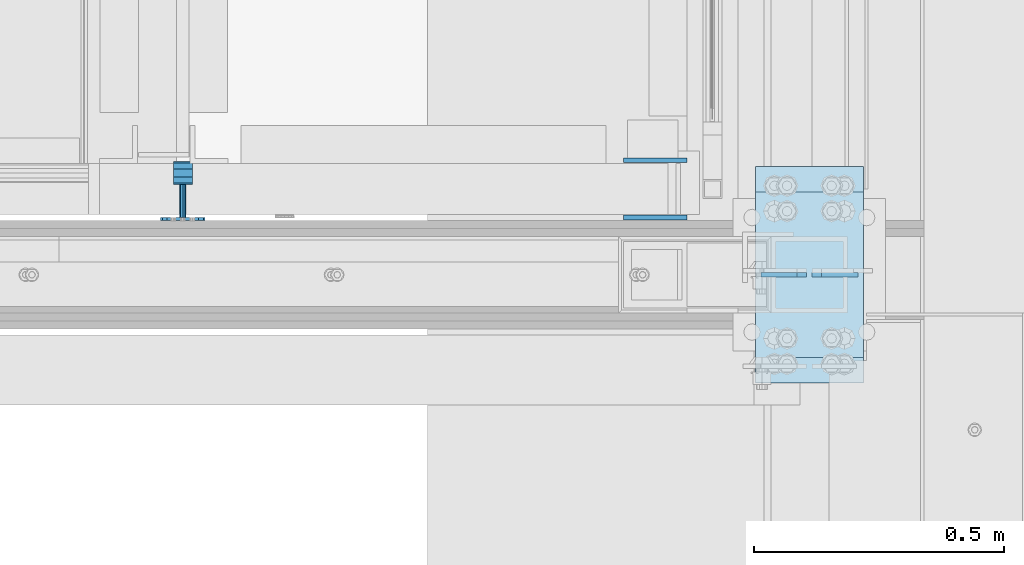
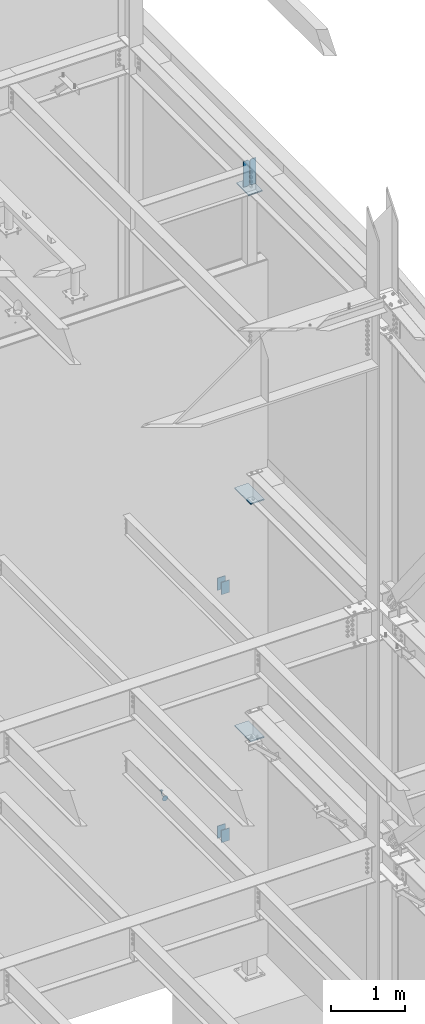
# One storey, part 1097 of 1179: 10 plates, 7 elements without a shape of their own.
"""IFC2X3 building model written with IfcOpenShell, lengths in millimetres."""

import ifcopenshell
import ifcopenshell.guid

model = None  # the IFC model being written
_history = None  # IfcOwnerHistory: only IFC2X3 demands one
_inside = {}  # id of a spatial element -> (the spatial element, [elements in it])
_under = {}  # id of a project, library or spatial element -> (it, [spatial elements below it])
_declared = {}  # id of a project -> (the project, [libraries it declares])
_typed = {}  # id of a type object -> (the type object, [elements of that type])
_made_of = {}  # id of a material, layer set ... -> (it, [elements and type objects made of it])


def new_model(schema):
    """Start an empty IFC model of exactly this schema.

    Asked for "IFC4X3", IfcOpenShell would pick the latest addendum, in which some entities
    have other attributes; the version numbers below select the first issue.
    IFC2X3 requires an IfcOwnerHistory on every rooted entity: one is made here for all.
    """
    global model, _history
    if schema == "IFC4X3":
        model = ifcopenshell.file(schema_version=(4, 3, 0, 0))
    else:
        model = ifcopenshell.file(schema=schema)
    _inside.clear()
    _under.clear()
    _declared.clear()
    _typed.clear()
    _made_of.clear()
    _history = None
    if model.schema == "IFC2X3":
        org = make("IfcOrganization", Name="unknown")
        user = make(
            "IfcPersonAndOrganization",
            ThePerson=make("IfcPerson", FamilyName="unknown"),
            TheOrganization=org,
        )
        app = make(
            "IfcApplication",
            ApplicationDeveloper=org,
            Version="unknown",
            ApplicationFullName="unknown",
            ApplicationIdentifier="unknown",
        )
        _history = make(
            "IfcOwnerHistory",
            OwningUser=user,
            OwningApplication=app,
            ChangeAction="ADDED",
            CreationDate=0,
        )
    return model


def make(cls, **values):
    """One entity of the class cls with the attributes given. An attribute that is None is left unset."""
    return model.create_entity(
        cls, **{name: value for name, value in values.items() if value is not None}
    )


def rooted(cls, **values):
    """An entity with a GlobalId (a new one), such as an element, a storey or a relation."""
    return make(cls, GlobalId=ifcopenshell.guid.new(), OwnerHistory=_history, **values)


def si_unit(unit_type, name, prefix=None):
    """IfcSIUnit, for example si_unit("LENGTHUNIT", "METRE", prefix="MILLI")."""
    return make("IfcSIUnit", UnitType=unit_type, Prefix=prefix, Name=name)


def assignment(units):
    """IfcUnitAssignment: the units of a project."""
    return None if units is None else make("IfcUnitAssignment", Units=units)


def point(xyz):
    """IfcCartesianPoint."""
    return None if xyz is None else make("IfcCartesianPoint", Coordinates=xyz)


def direction(xyz):
    """IfcDirection."""
    return None if xyz is None else make("IfcDirection", DirectionRatios=xyz)


def frame(location, z_axis=None, x_axis=None):
    """IfcAxis2Placement3D, a coordinate frame: its origin and axes. An axis left out is left unset."""
    return make(
        "IfcAxis2Placement3D",
        Location=point(location),
        Axis=direction(z_axis),
        RefDirection=direction(x_axis),
    )


def origin_with_axes():
    """The frame at (0, 0, 0) with the z axis (0, 0, 1) and the x axis (1, 0, 0) written out."""
    return frame((0.0, 0.0, 0.0), z_axis=(0.0, 0.0, 1.0), x_axis=(1.0, 0.0, 0.0))


def place(relative_to, where):
    """IfcLocalPlacement: puts the frame where relative to a parent placement (None: the world)."""
    return make(
        "IfcLocalPlacement", PlacementRelTo=relative_to, RelativePlacement=where
    )


def context(
    kind, dimensions, precision=None, world=None, true_north=None, identifier=None
):
    """IfcGeometricRepresentationContext, for example the 3D "Model" context."""
    return make(
        "IfcGeometricRepresentationContext",
        ContextIdentifier=identifier,
        ContextType=kind,
        CoordinateSpaceDimension=dimensions,
        Precision=precision,
        WorldCoordinateSystem=world,
        TrueNorth=true_north,
    )


def subcontext(parent, identifier, kind, view, scale=None):
    """IfcGeometricRepresentationSubContext, for example "Body" below "Model"."""
    return make(
        "IfcGeometricRepresentationSubContext",
        ContextIdentifier=identifier,
        ContextType=kind,
        ParentContext=parent,
        TargetScale=scale,
        TargetView=view,
    )


def project(units=None, contexts=None):
    """IfcProject with its units and contexts."""
    return rooted(
        "IfcProject",
        Name="project",
        RepresentationContexts=contexts,
        UnitsInContext=assignment(units),
    )


def spatial(cls, under=None, at=None, **own):
    """A site, building, storey or space (cls), placed at a placement, below another one or the project."""
    s = rooted(cls, ObjectPlacement=at, **own)
    if under is not None:
        _under.setdefault(under.id(), (under, []))[1].append(s)
    return s


def faces_of(points, faces, orient=None, outer=None):
    """IfcFace entities. A face is a list of loops; a loop is a list of indices into points, from 0.

    orient and outer hold one flag for each loop. By default every Orientation is true, the
    first loop of a face is its IfcFaceOuterBound and the others are IfcFaceBound.
    """
    made = []
    for i, loops in enumerate(faces):
        bounds = []
        for j, loop in enumerate(loops):
            is_outer = j == 0 if outer is None else outer[i][j]
            bounds.append(
                make(
                    "IfcFaceOuterBound" if is_outer else "IfcFaceBound",
                    Bound=make("IfcPolyLoop", Polygon=[points[k] for k in loop]),
                    Orientation=True if orient is None else orient[i][j],
                )
            )
        made.append(make("IfcFace", Bounds=bounds))
    return made


def faceted_brep(points, faces, orient=None, outer=None, voids=None):
    """IfcFacetedBrep: a solid bounded by flat faces; with voids (closed shells), ...WithVoids."""
    shared = [point(p) for p in points]
    hull = make("IfcClosedShell", CfsFaces=faces_of(shared, faces, orient, outer))
    if voids is None:
        return make("IfcFacetedBrep", Outer=hull)
    return make(
        "IfcFacetedBrepWithVoids",
        Outer=hull,
        Voids=[
            make(cls, CfsFaces=faces_of(shared, fs, o, b)) for cls, fs, o, b in voids
        ],
    )


def shape(context_of_items, identifier, shape_type, items):
    """IfcShapeRepresentation: the items that make up one representation, for example the "Body"."""
    return make(
        "IfcShapeRepresentation",
        ContextOfItems=context_of_items,
        RepresentationIdentifier=identifier,
        RepresentationType=shape_type,
        Items=items,
    )


def material(Name=None, Category=None):
    """IfcMaterial."""
    return make("IfcMaterial", Name=Name, Category=Category)


def made_of(thing, what):
    """Note that an element or type object is made of a material, layer set ...; save() writes the relation."""
    if what is not None:
        _made_of.setdefault(what.id(), (what, []))[1].append(thing)
    return thing


def type_object(cls, material=None, **own):
    """A type object (cls), such as IfcWallType, which elements share."""
    return made_of(rooted(cls, **own), material)


def element(
    cls,
    number,
    at=None,
    inside=None,
    cuts=None,
    type_object=None,
    material=None,
    context=None,
    identifier="Body",
    shape_type=None,
    held_by="IfcProductDefinitionShape",
    body=None,
    shapes=None,
    **own,
):
    """One element of the class cls, such as IfcWall. Its Tag is "e" and its number.

    at: its placement. inside: the storey or other place that contains it. cuts: it is an
    opening in that element (IfcRelVoidsElement). A single representation is given by context,
    identifier, shape_type and body (its items); several are given by shapes. held_by: the class
    of the entity that holds the representations. save() writes the other relations.
    """
    e = rooted(cls, Tag="e%d" % number, ObjectPlacement=at, **own)
    if body is not None:
        shapes = [shape(context, identifier, shape_type, body)]
    if shapes is not None:
        e.Representation = make(held_by, Representations=shapes)
    if inside is not None:
        _inside.setdefault(inside.id(), (inside, []))[1].append(e)
    if cuts is not None:
        rooted(
            "IfcRelVoidsElement", RelatingBuildingElement=cuts, RelatedOpeningElement=e
        )
    if type_object is not None:
        _typed.setdefault(type_object.id(), (type_object, []))[1].append(e)
    return made_of(e, material)


def aggregate(whole, parts):
    """IfcRelAggregates: a whole, such as a stair, and the parts it consists of."""
    return rooted("IfcRelAggregates", RelatingObject=whole, RelatedObjects=parts)


def save(model, path):
    """Write the relations noted so far, then the file.

    IfcRelAggregates (storeys below a building ...), IfcRelContainedInSpatialStructure (elements
    in a storey), IfcRelDefinesByType, IfcRelAssociatesMaterial and IfcRelDeclares: one each for
    every whole, place, type object, material and project.
    """
    for whole, parts in _under.values():
        aggregate(whole, parts)
    for where, things in _inside.values():
        rooted(
            "IfcRelContainedInSpatialStructure",
            RelatedElements=things,
            RelatingStructure=where,
        )
    for kind, things in _typed.values():
        rooted("IfcRelDefinesByType", RelatedObjects=things, RelatingType=kind)
    for what, things in _made_of.values():
        rooted("IfcRelAssociatesMaterial", RelatedObjects=things, RelatingMaterial=what)
    for by, libraries in _declared.values():
        rooted("IfcRelDeclares", RelatingContext=by, RelatedDefinitions=libraries)
    model.write(path)


model = new_model("IFC2X3")

# Units and contexts
model_context = context("Model", 3, precision=1e-05, world=origin_with_axes())
body_context = subcontext(model_context, "Body", "Model", "MODEL_VIEW")
ifc_project = project(units=[si_unit("LENGTHUNIT", "METRE", prefix="MILLI"), si_unit("AREAUNIT", "SQUARE_METRE"), si_unit("VOLUMEUNIT", "CUBIC_METRE"), si_unit("MASSUNIT", "GRAM", prefix="KILO"), si_unit("TIMEUNIT", "SECOND"), si_unit("PLANEANGLEUNIT", "RADIAN"), si_unit("SOLIDANGLEUNIT", "STERADIAN"), si_unit("THERMODYNAMICTEMPERATUREUNIT", "DEGREE_CELSIUS"), si_unit("LUMINOUSINTENSITYUNIT", "LUMEN")], contexts=[model_context])

# Site, building, storey
site_placement = place(None, origin_with_axes())
site = spatial("IfcSite", under=ifc_project, at=site_placement, CompositionType="ELEMENT")
building_placement = place(site_placement, origin_with_axes())
building = spatial("IfcBuilding", under=site, at=building_placement, Name="Undefined", CompositionType="ELEMENT")
storey_placement = place(building_placement, origin_with_axes())
storey = spatial("IfcBuildingStorey", under=building, at=storey_placement, Name="Undefined", CompositionType="ELEMENT", Elevation=0.0)

# Assembly, plates
assembly_1_placement = place(storey_placement, origin_with_axes())
assembly_1 = element("IfcElementAssembly", 1, at=assembly_1_placement, inside=storey, Name="BEAM", AssemblyPlace="NOTDEFINED", PredefinedType="RIGID_FRAME")
ifc_material_1 = material(Name="STEEL/A36")
plate_type_1 = type_object("IfcPlateType", PredefinedType="NOTDEFINED")
plate_1_placement = place(assembly_1_placement, frame((24063.325, 38214.2999999749, 6191.25000000012), z_axis=(-1.0, 0.0, 0.0), x_axis=(0.0, 0.0, -1.0)))
plate_1 = element("IfcPlate", 2, at=plate_1_placement, type_object=plate_type_1, material=ifc_material_1, Name="PLATE", context=body_context, shape_type="Brep", body=[
    faceted_brep([(0.0, -4.76249999999709, 0.0), (0.0, -4.76249999999709, 127.0), (0.0, 4.76249999999709, 127.0), (0.0, 4.76249999999709, 0.0), (203.2, -4.76249999999709, 127.0), (203.2, 4.76249999999709, 127.0), (203.2, -4.76249999999709, 0.0), (203.2, 4.76249999999709, 0.0)], [[[0, 1, 2, 3]], [[1, 4, 5, 2]], [[4, 6, 7, 5]], [[6, 0, 3, 7]], [[5, 7, 3, 2]], [[6, 4, 1, 0]]]),
])
plate_2_placement = place(assembly_1_placement, frame((24063.325, 38099.9999999749, 6191.25000000012), z_axis=(-1.0, 0.0, 0.0), x_axis=(0.0, 0.0, -1.0)))
plate_2 = element("IfcPlate", 3, at=plate_2_placement, type_object=plate_type_1, material=ifc_material_1, Name="PLATE", context=body_context, shape_type="Brep", body=[
    faceted_brep([(0.0, -4.76249999999709, 0.0), (0.0, -4.76249999999709, 127.0), (0.0, 4.76249999999709, 127.0), (0.0, 4.76249999999709, 0.0), (203.2, -4.76249999999709, 127.0), (203.2, 4.76249999999709, 127.0), (203.2, -4.76249999999709, 0.0), (203.2, 4.76249999999709, 0.0)], [[[0, 1, 2, 3]], [[1, 4, 5, 2]], [[4, 6, 7, 5]], [[6, 0, 3, 7]], [[5, 7, 3, 2]], [[6, 4, 1, 0]]]),
])
aggregate(assembly_1, [plate_1, plate_2])

assembly_2_placement = place(storey_placement, origin_with_axes())
assembly_2 = element("IfcElementAssembly", 4, at=assembly_2_placement, inside=storey, Name="BEAM", AssemblyPlace="NOTDEFINED", PredefinedType="RIGID_FRAME")
plate_3_placement = place(assembly_2_placement, frame((24063.3250004143, 38214.2999999749, 2105.02499935051), z_axis=(-1.0, 0.0, 0.0), x_axis=(0.0, 0.0, -1.0)))
plate_3 = element("IfcPlate", 5, at=plate_3_placement, type_object=plate_type_1, material=ifc_material_1, Name="PLATE", context=body_context, shape_type="Brep", body=[
    faceted_brep([(0.0, -4.76249999999709, 0.0), (0.0, -4.76249999999709, 127.0), (0.0, 4.76249999999709, 127.0), (0.0, 4.76249999999709, 0.0), (203.2, -4.76249999999709, 127.0), (203.2, 4.76249999999709, 127.0), (203.2, -4.76249999999709, 0.0), (203.2, 4.76249999999709, 0.0)], [[[0, 1, 2, 3]], [[1, 4, 5, 2]], [[4, 6, 7, 5]], [[6, 0, 3, 7]], [[5, 7, 3, 2]], [[6, 4, 1, 0]]]),
])
plate_4_placement = place(assembly_2_placement, frame((24063.3250004143, 38099.9999999749, 2105.02499935051), z_axis=(-1.0, 0.0, 0.0), x_axis=(0.0, 0.0, -1.0)))
plate_4 = element("IfcPlate", 6, at=plate_4_placement, type_object=plate_type_1, material=ifc_material_1, Name="PLATE", context=body_context, shape_type="Brep", body=[
    faceted_brep([(0.0, -4.76249999999709, 0.0), (0.0, -4.76249999999709, 127.0), (0.0, 4.76249999999709, 127.0), (0.0, 4.76249999999709, 0.0), (203.2, -4.76249999999709, 127.0), (203.2, 4.76249999999709, 127.0), (203.2, -4.76249999999709, 0.0), (203.2, 4.76249999999709, 0.0)], [[[0, 1, 2, 3]], [[1, 4, 5, 2]], [[4, 6, 7, 5]], [[6, 0, 3, 7]], [[5, 7, 3, 2]], [[6, 4, 1, 0]]]),
])
aggregate(assembly_2, [plate_3, plate_4])

# Assembly, plate
assembly_3_placement = place(storey_placement, origin_with_axes())
assembly_3 = element("IfcElementAssembly", 7, at=assembly_3_placement, inside=storey, Name="HANDRAIL", AssemblyPlace="NOTDEFINED", PredefinedType="RIGID_FRAME")
ifc_material_2 = material(Name="STEEL/BUY-OUT")
plate_type_2 = type_object("IfcPlateType", PredefinedType="NOTDEFINED")
plate_5_placement = place(assembly_3_placement, frame((23101.299999827, 38096.8249999748, 2898.77499944318), z_axis=(0.0, 0.0, 1.0), x_axis=(-1.0, 0.0, 0.0)))
plate_5 = element("IfcPlate", 8, at=plate_5_placement, type_object=plate_type_2, material=ifc_material_2, Name="BRACKET", context=body_context, shape_type="Brep", body=[
    faceted_brep([(3.38355483805572, -3.17500000000291, 61.4602780976829), (13.0191037998557, -3.17500000000291, 75.8808962003231), (13.0191037998557, 3.17500000000291, 75.8808962003231), (3.38355483805572, 3.17500000000291, 61.4602780976829), (27.439721902505, -3.17500000000291, 85.5164451621013), (27.439721902505, 3.17500000000291, 85.5164451621013), (44.449999237233, -3.17500000000291, 88.900000000056), (44.449999237233, 3.17500000000291, 88.900000000056), (61.4602780978275, -3.17500000000291, 85.5164451621104), (61.4602780978275, 3.17500000000291, 85.5164451621104), (75.8808962004478, -3.17500000000291, 75.8808962003413), (75.8808962004478, 3.17500000000291, 75.8808962003413), (85.5164451621931, -3.17500000000291, 61.4602780977075), (85.5164451621931, 3.17500000000291, 61.4602780977075), (88.9000000001142, -3.17500000000291, 44.4500007629867), (88.9000000001142, 3.17500000000291, 44.4500007629867), (85.5164451621349, -3.17500000000291, 27.4397219023849), (85.5164451621349, 3.17500000000291, 27.4397219023849), (75.880896200335, -3.17500000000291, 13.0191037997447), (75.880896200335, 3.17500000000291, 13.0191037997447), (61.460278097682, -3.17500000000291, 3.38355483796659), (61.460278097682, 3.17500000000291, 3.38355483796659), (44.450000762954, -3.17500000000291, 1.18234311230481e-11), (44.450000762954, 3.17500000000291, 1.18234311230481e-11), (27.4397219023631, -3.17500000000291, 3.38355483795749), (27.4397219023631, 3.17500000000291, 3.38355483795749), (13.0191037997429, -3.17500000000291, 13.0191037997274), (13.0191037997429, 3.17500000000291, 13.0191037997274), (3.38355483799751, -3.17500000000291, 27.4397219023613), (3.38355483799751, 3.17500000000291, 27.4397219023613), (7.6397554948926e-11, -3.17500000000291, 44.4500007629631), (7.6397554948926e-11, 3.17500000000291, 44.4500007629631), (50.7999999913809, -79.375000189706, 44.450000918423), (48.9401280518978, -79.375000189706, 39.9598728578721), (48.9401280518978, -3.17500000000291, 39.9598728578721), (50.7999999913809, -3.17500000000291, 44.450000918423), (44.4499999913533, -79.375000189706, 38.1000009183936), (44.4499999913533, -3.17500000000291, 38.1000009183936), (39.9598719308196, -79.375000189706, 39.9598728578549), (39.9598719308196, -3.17500000000291, 39.9598728578549), (38.0999999913656, -79.375000189706, 44.4500009184003), (38.0999999913656, -3.17500000000291, 44.4500009184003), (39.9598719308487, -79.375000189706, 48.940128978953), (39.9598719308487, -3.17500000000291, 48.940128978953), (44.4499999903783, -79.375000189706, 50.8000009184298), (48.9401280519305, -79.375000189706, 48.9401289789685), (48.9401280519305, -3.17500000000291, 48.9401289789685), (44.4499999913933, -3.17500000000291, 50.8000009184325), (48.940128050941, -83.4799360644611, 50.0400432323731), (50.7999999909662, -85.7250000949134, 46.1514782660752), (48.9401280520542, -87.9700641252057, 42.2629132991351), (44.4499999917462, -88.9000000947854, 40.6522169510108), (39.9598719309761, -87.9700641248055, 42.2629132975717), (38.0999999909509, -85.7250000943604, 46.1514782638696), (39.9598719298592, -83.4799360640682, 50.0400432308115), (44.4499999901709, -82.5500000944885, 51.6507395789349), (44.4499999895997, -84.8742613387294, 53.9750008233668), (48.9401280502061, -86.4849576864799, 53.0450648546439), (39.9598719291243, -86.4849576858032, 53.0450648527949), (38.0999999898122, -90.3735226524441, 50.8000008223462), (39.9598719294336, -94.262087619376, 48.554936792666), (44.4499999900399, -95.8727839671337, 47.6250008239376), (48.9401280505153, -94.2620876200599, 48.5549367945105), (50.7999999898311, -90.3735226534118, 50.8000008249601), (48.940128049202, -87.5848719388305, 57.150000729499), (50.7999999882741, -92.0749999995314, 57.1500007303257), (44.4499999882682, -85.7249999989726, 57.1500007282275), (39.9598719281203, -87.5848719380447, 57.1500007272562), (38.0999999882624, -92.0749999984182, 57.1500007271543), (39.9598719273345, -96.5651280591119, 57.150000727981), (44.4499999877116, -98.4249999989697, 57.1500007292507), (48.9401280484162, -96.5651280598977, 57.150000730222), (48.94012803636, -96.5651280554303, 107.980205186974), (50.7999999758504, -92.0749999949039, 107.980205187367), (44.4499999758082, -98.4249999948734, 107.980205185997), (39.9598719152818, -96.5651280553866, 107.980205185009), (38.0999999758387, -92.0749999948384, 107.980205184591), (39.9598719153255, -87.5848719343194, 107.980205184981), (44.4499999758445, -85.7249999948763, 107.980205185959), (48.9401280364073, -87.584871934363, 107.980205186946), (63.4999999710089, -112.173153287971, 121.386761918008), (25.3999999709486, -112.173153273812, 121.386761909694), (25.3999999709413, -115.348153273233, 115.887500595331), (63.499999970998, -115.348153287392, 115.887500603646), (63.4999999770953, -99.950838506069, 114.330205190187), (25.3999999770385, -99.9508384918445, 114.330205181834), (63.4999999830179, -84.3037932516017, 114.330205190117), (25.3999999829539, -84.3037932373336, 114.330205181805), (63.4999999860993, -72.081478471373, 121.386761924126), (25.3999999860353, -72.0814784571267, 121.386761915784), (25.3999999849657, -82.6023158642492, 107.980205181794), (25.3999999777625, -101.652315863423, 107.98020518183), (25.3999999884181, -68.9064784552756, 115.887500602809), (63.4999999778265, -101.652315877654, 107.980205190185), (63.4999999850261, -82.6023158785247, 107.980205190103), (63.4999999884785, -68.906478469522, 115.887500611152)], [[[0, 1, 2, 3]], [[1, 4, 5, 2]], [[4, 6, 7, 5]], [[6, 8, 9, 7]], [[8, 10, 11, 9]], [[10, 12, 13, 11]], [[12, 14, 15, 13]], [[14, 16, 17, 15]], [[16, 18, 19, 17]], [[18, 20, 21, 19]], [[20, 22, 23, 21]], [[22, 24, 25, 23]], [[24, 26, 27, 25]], [[26, 28, 29, 27]], [[28, 30, 31, 29]], [[2, 5, 7, 9, 11, 13, 15, 17, 19, 21, 23, 25, 27, 29, 31, 3]], [[30, 0, 3, 31]], [[32, 33, 34, 35]], [[33, 36, 37, 34]], [[36, 38, 39, 37]], [[38, 40, 41, 39]], [[40, 42, 43, 41]], [[44, 45, 46, 47]], [[42, 44, 47, 43]], [[28, 26, 24, 22, 20, 18, 16, 14, 12, 10, 8, 6, 4, 1, 0, 30], [46, 35, 34, 37, 39, 41, 43, 47]], [[45, 32, 35, 46]], [[32, 45, 48, 49]], [[33, 32, 49, 50]], [[36, 33, 50, 51]], [[38, 36, 51, 52]], [[40, 38, 52, 53]], [[42, 40, 53, 54]], [[44, 42, 54, 55]], [[45, 44, 55, 48]], [[55, 56, 57, 48]], [[54, 58, 56, 55]], [[53, 59, 58, 54]], [[52, 60, 59, 53]], [[51, 61, 60, 52]], [[50, 62, 61, 51]], [[49, 63, 62, 50]], [[48, 57, 63, 49]], [[57, 64, 65, 63]], [[56, 66, 64, 57]], [[58, 67, 66, 56]], [[59, 68, 67, 58]], [[60, 69, 68, 59]], [[61, 70, 69, 60]], [[62, 71, 70, 61]], [[63, 65, 71, 62]], [[72, 71, 65, 73]], [[74, 70, 71, 72]], [[75, 69, 70, 74]], [[76, 68, 69, 75]], [[77, 67, 68, 76]], [[78, 66, 67, 77]], [[79, 64, 66, 78]], [[73, 65, 64, 79]], [[80, 81, 82, 83]], [[81, 80, 84, 85]], [[85, 84, 86, 87]], [[87, 86, 88, 89]], [[90, 91, 82, 81, 85, 87, 89, 92]], [[83, 82, 91, 93]], [[86, 84, 80, 83, 93, 94, 95, 88]], [[89, 88, 95, 92]], [[94, 90, 92, 95]], [[93, 91, 90, 94], [78, 77, 76, 75, 74, 72, 73, 79]]]),
])
aggregate(assembly_3, [plate_5])

# Assembly, plates
assembly_4_placement = place(storey_placement, origin_with_axes())
assembly_4 = element("IfcElementAssembly", 9, at=assembly_4_placement, inside=storey, Name="BEAM", AssemblyPlace="NOTDEFINED", PredefinedType="RIGID_FRAME")
plate_type_3 = type_object("IfcPlateType", PredefinedType="NOTDEFINED")
plate_6_placement = place(assembly_4_placement, frame((24404.6375, 37985.7, 13098.4625), z_axis=(0.0, 0.0, -1.0), x_axis=(-1.0, 0.0, 0.0)))
plate_6 = element("IfcPlate", 10, at=plate_6_placement, type_object=plate_type_3, material=ifc_material_1, Name="PLATE", context=body_context, shape_type="Brep", body=[
    faceted_brep([(0.0, -4.76249999999709, 0.0), (-9.09494701772928e-13, -4.76250000000255, 425.450012207031), (9.09494701772928e-13, 4.76249999999891, 425.450012207031), (0.0, 4.76249999999709, 0.0), (72.2312502153181, -4.76249999999709, 425.45), (72.2312502153181, 4.76249999999709, 425.45), (91.28125, -4.76249999999709, 406.40000076294), (91.28125, 4.76249999999709, 406.40000076294), (91.28125, -4.76250000000073, 19.0499992370605), (91.28125, 4.76250000000073, 19.0499992370605), (72.2312502153181, -4.76249999999709, 0.0), (72.2312502153181, 4.76249999999709, 0.0)], [[[0, 1, 2, 3]], [[1, 4, 5, 2]], [[4, 6, 7, 5]], [[6, 8, 9, 7]], [[8, 10, 11, 9]], [[10, 0, 3, 11]], [[5, 7, 9, 11, 3, 2]], [[10, 8, 6, 4, 1, 0]]]),
])
plate_7_placement = place(assembly_4_placement, frame((24210.9625, 37985.7, 13098.4625), z_axis=(0.0, 0.0, -1.0), x_axis=(1.0, 0.0, 0.0)))
plate_7 = element("IfcPlate", 11, at=plate_7_placement, type_object=plate_type_3, material=ifc_material_1, Name="PLATE", context=body_context, shape_type="Brep", body=[
    faceted_brep([(0.0, -4.76249999999709, 0.0), (-9.09494701772928e-13, -4.76250000000255, 425.450012207031), (9.09494701772928e-13, 4.76249999999891, 425.450012207031), (0.0, 4.76249999999709, 0.0), (72.2312502153181, -4.76249999999709, 425.45), (72.2312502153181, 4.76249999999709, 425.45), (91.28125, -4.76249999999709, 406.40000076294), (91.28125, 4.76249999999709, 406.40000076294), (91.28125, -4.76250000000073, 19.0499992370605), (91.28125, 4.76250000000073, 19.0499992370605), (72.2312502153181, -4.76249999999709, 0.0), (72.2312502153181, 4.76249999999709, 0.0)], [[[0, 1, 2, 3]], [[1, 4, 5, 2]], [[4, 6, 7, 5]], [[6, 8, 9, 7]], [[8, 10, 11, 9]], [[10, 0, 3, 11]], [[5, 7, 9, 11, 3, 2]], [[10, 8, 6, 4, 1, 0]]]),
])
aggregate(assembly_4, [plate_6, plate_7])

# Assembly, plate
assembly_5_placement = place(storey_placement, origin_with_axes())
assembly_5 = element("IfcElementAssembly", 12, at=assembly_5_placement, inside=storey, Name="COLUMN", AssemblyPlace="NOTDEFINED", PredefinedType="RIGID_FRAME")
plate_type_4 = type_object("IfcPlateType", PredefinedType="NOTDEFINED")
plate_8_placement = place(assembly_5_placement, frame((24415.75, 37769.8, 7588.25), z_axis=(0.0, 1.0, 0.0), x_axis=(-1.0, 0.0, 0.0)))
plate_8 = element("IfcPlate", 13, at=plate_8_placement, type_object=plate_type_4, material=ifc_material_1, Name="PLATE", context=body_context, shape_type="Brep", body=[
    faceted_brep([(0.0, -9.52499999999964, 0.0), (0.0, -9.52499999999964, 431.800000000003), (0.0, 9.52499999999964, 431.800000000003), (0.0, 9.52499999999964, 0.0), (215.900000000001, -9.52499999999964, 431.800000000003), (215.900000000001, 9.52499999999964, 431.800000000003), (215.900000000001, -9.52499999999964, 0.0), (215.900000000001, 9.52499999999964, 0.0)], [[[0, 1, 2, 3]], [[1, 4, 5, 2]], [[4, 6, 7, 5]], [[6, 0, 3, 7]], [[5, 7, 3, 2]], [[6, 4, 1, 0]]]),
])
aggregate(assembly_5, [plate_8])

assembly_6_placement = place(storey_placement, origin_with_axes())
assembly_6 = element("IfcElementAssembly", 14, at=assembly_6_placement, inside=storey, Name="COLUMN", AssemblyPlace="NOTDEFINED", PredefinedType="RIGID_FRAME")
plate_9_placement = place(assembly_6_placement, frame((24415.75, 37769.8, 3673.475), z_axis=(0.0, 1.0, 0.0), x_axis=(-1.0, 0.0, 0.0)))
plate_9 = element("IfcPlate", 15, at=plate_9_placement, type_object=plate_type_4, material=ifc_material_1, Name="PLATE", context=body_context, shape_type="Brep", body=[
    faceted_brep([(0.0, -9.52499999999964, 0.0), (0.0, -9.52499999999964, 431.800000000003), (0.0, 9.52499999999964, 431.800000000003), (0.0, 9.52499999999964, 0.0), (215.900000000001, -9.52499999999964, 431.800000000003), (215.900000000001, 9.52499999999964, 431.800000000003), (215.900000000001, -9.52499999999964, 0.0), (215.900000000001, 9.52499999999964, 0.0)], [[[0, 1, 2, 3]], [[1, 4, 5, 2]], [[4, 6, 7, 5]], [[6, 0, 3, 7]], [[5, 7, 3, 2]], [[6, 4, 1, 0]]]),
])
aggregate(assembly_6, [plate_9])

assembly_7_placement = place(storey_placement, origin_with_axes())
assembly_7 = element("IfcElementAssembly", 16, at=assembly_7_placement, inside=storey, Name="COLUMN", AssemblyPlace="NOTDEFINED", PredefinedType="RIGID_FRAME")
plate_10_placement = place(assembly_7_placement, frame((24415.75, 37820.6, 12642.85), z_axis=(0.0, 1.0, 0.0), x_axis=(-1.0, 0.0, 0.0)))
plate_10 = element("IfcPlate", 17, at=plate_10_placement, type_object=plate_type_4, material=ifc_material_1, Name="PLATE", context=body_context, shape_type="Brep", body=[
    faceted_brep([(0.0, -9.52499999999964, 0.0), (0.0, -9.52499999999964, 330.200012207031), (0.0, 9.52499999999964, 330.200012207031), (0.0, 9.52499999999964, 0.0), (215.899993896484, -9.52499999999964, 330.200012207031), (215.899993896484, 9.52499999999964, 330.200012207031), (215.900000000001, -9.52499999999964, 0.0), (215.900000000001, 9.52499999999964, 0.0)], [[[0, 1, 2, 3]], [[1, 4, 5, 2]], [[4, 6, 7, 5]], [[6, 0, 3, 7]], [[5, 7, 3, 2]], [[6, 4, 1, 0]]]),
])
aggregate(assembly_7, [plate_10])

save(model, "model.ifc")
